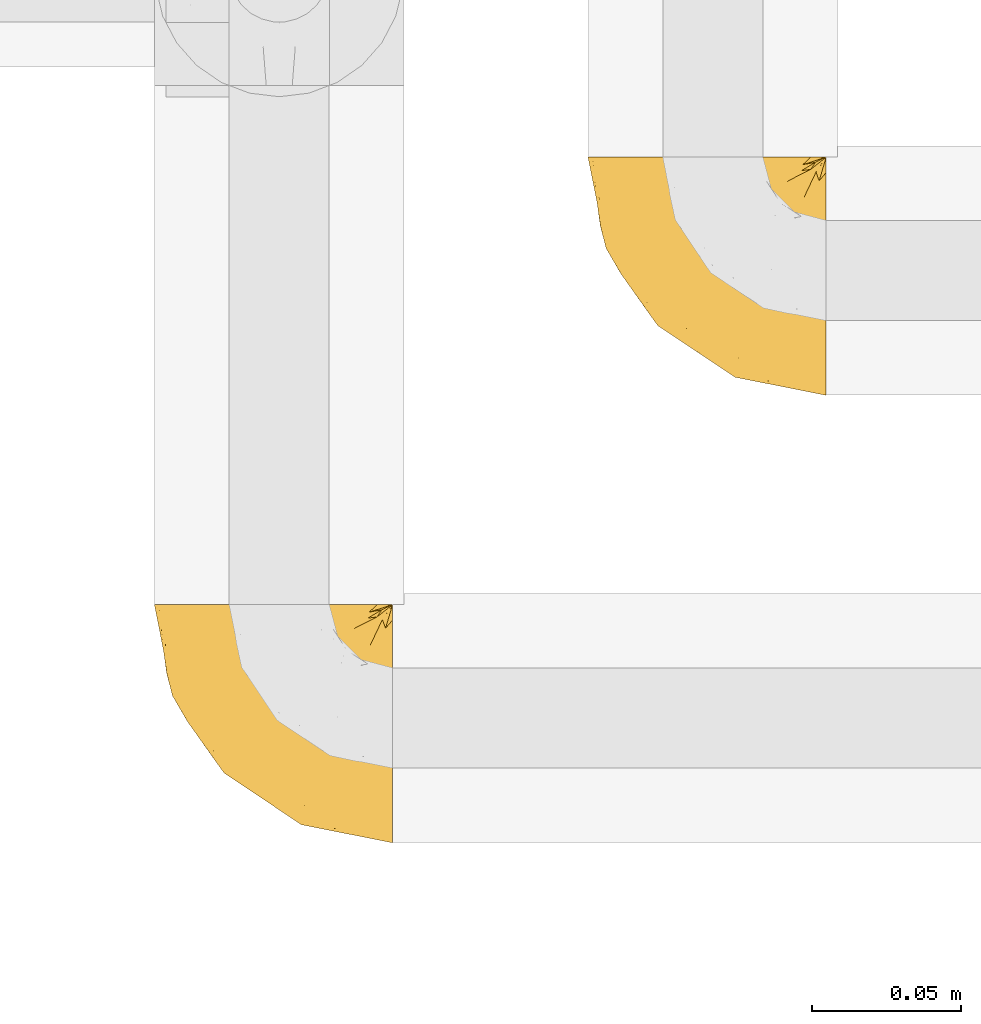
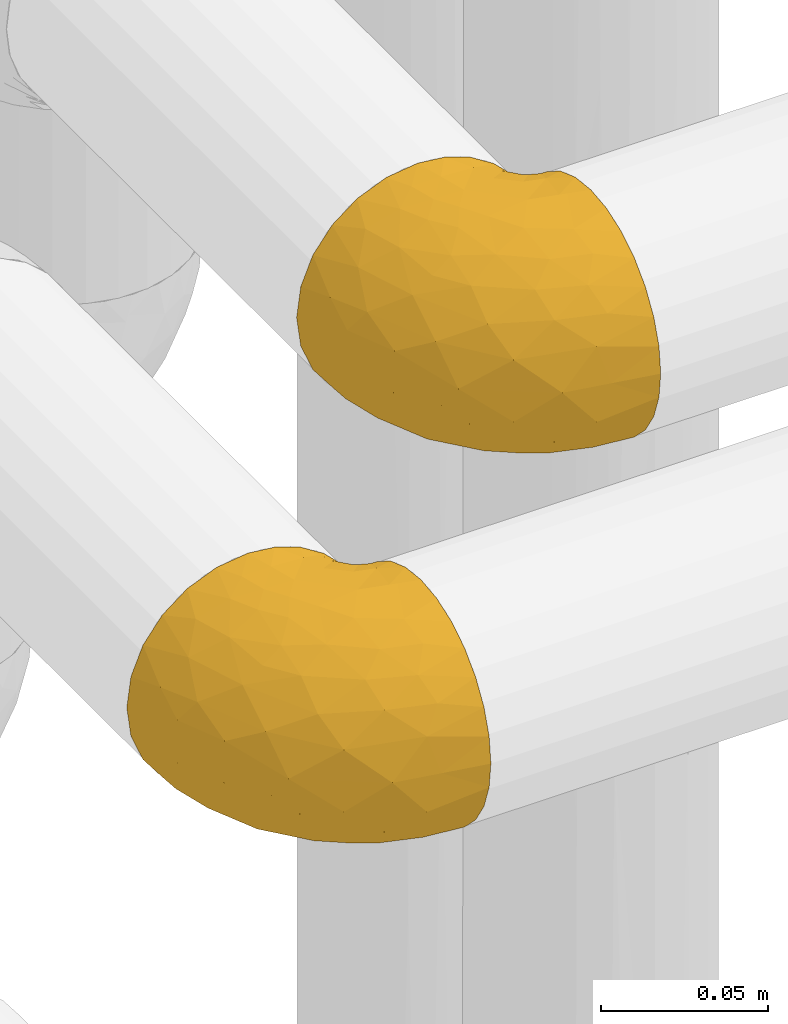
# One storey, part 57 of 827: 2 coverings.
"""IFC2X3 building model written with IfcOpenShell, lengths in millimetres."""

from ifc_helpers import new_model, entity, si_unit, converted_unit, derived_unit, direction, frame, origin, place, context, subcontext, project, spatial, faceted_brep, element, save


model = new_model("IFC2X3")

# Units and contexts
model_context = context("Model", 3, precision=0.01, world=origin(), true_north=direction((6.12303176911189e-17, 1.0)))
body_context = subcontext(model_context, "Body", "Model", "MODEL_VIEW")
ifc_project = project(units=[si_unit("LENGTHUNIT", "METRE", prefix="MILLI"), si_unit("AREAUNIT", "SQUARE_METRE"), si_unit("VOLUMEUNIT", "CUBIC_METRE"), converted_unit("PLANEANGLEUNIT", "DEGREE", entity("IfcRatioMeasure", 0.0174532925199433), si_unit("PLANEANGLEUNIT", "RADIAN"), dimensions=[0, 0, 0, 0, 0, 0, 0]), si_unit("MASSUNIT", "GRAM", prefix="KILO"), derived_unit("MASSDENSITYUNIT", [(si_unit("MASSUNIT", "GRAM", prefix="KILO"), 1), (si_unit("LENGTHUNIT", "METRE"), -3)]), derived_unit("MOMENTOFINERTIAUNIT", [(si_unit("LENGTHUNIT", "METRE"), 4)]), si_unit("TIMEUNIT", "SECOND"), si_unit("FREQUENCYUNIT", "HERTZ"), si_unit("THERMODYNAMICTEMPERATUREUNIT", "DEGREE_CELSIUS"), derived_unit("THERMALTRANSMITTANCEUNIT", [(si_unit("MASSUNIT", "GRAM", prefix="KILO"), 1), (si_unit("THERMODYNAMICTEMPERATUREUNIT", "KELVIN"), -1), (si_unit("TIMEUNIT", "SECOND"), -3)]), derived_unit("VOLUMETRICFLOWRATEUNIT", [(si_unit("LENGTHUNIT", "METRE"), 3), (si_unit("TIMEUNIT", "SECOND"), -1)]), derived_unit("MASSFLOWRATEUNIT", [(si_unit("MASSUNIT", "GRAM", prefix="KILO"), 1), (si_unit("TIMEUNIT", "SECOND"), -1)]), derived_unit("ROTATIONALFREQUENCYUNIT", [(si_unit("TIMEUNIT", "SECOND"), -1)]), si_unit("ELECTRICCURRENTUNIT", "AMPERE"), si_unit("ELECTRICVOLTAGEUNIT", "VOLT"), si_unit("POWERUNIT", "WATT"), si_unit("FORCEUNIT", "NEWTON", prefix="KILO"), si_unit("ILLUMINANCEUNIT", "LUX"), si_unit("LUMINOUSFLUXUNIT", "LUMEN"), si_unit("LUMINOUSINTENSITYUNIT", "CANDELA"), derived_unit("USERDEFINED", [(si_unit("MASSUNIT", "GRAM", prefix="KILO"), -1), (si_unit("LENGTHUNIT", "METRE"), -2), (si_unit("TIMEUNIT", "SECOND"), 3), (si_unit("LUMINOUSFLUXUNIT", "LUMEN"), 1)]), derived_unit("LINEARVELOCITYUNIT", [(si_unit("LENGTHUNIT", "METRE"), 1), (si_unit("TIMEUNIT", "SECOND"), -1)]), si_unit("PRESSUREUNIT", "PASCAL"), derived_unit("USERDEFINED", [(si_unit("LENGTHUNIT", "METRE"), -2), (si_unit("MASSUNIT", "GRAM", prefix="KILO"), 1), (si_unit("TIMEUNIT", "SECOND"), -2)]), derived_unit("LINEARFORCEUNIT", [(si_unit("MASSUNIT", "GRAM", prefix="KILO"), 1), (si_unit("LENGTHUNIT", "METRE"), 1), (si_unit("TIMEUNIT", "SECOND"), -2), (si_unit("LENGTHUNIT", "METRE"), -1)]), derived_unit("PLANARFORCEUNIT", [(si_unit("MASSUNIT", "GRAM", prefix="KILO"), 1), (si_unit("LENGTHUNIT", "METRE"), 1), (si_unit("TIMEUNIT", "SECOND"), -2), (si_unit("LENGTHUNIT", "METRE"), -2)])], contexts=[model_context])

# Site, building, storey
site_placement = place(None, origin())
site = spatial("IfcSite", under=ifc_project, at=site_placement, CompositionType="ELEMENT")
building_placement = place(site_placement, origin())
building = spatial("IfcBuilding", under=site, at=building_placement, CompositionType="ELEMENT")
storey_placement = place(building_placement, frame((0.0, 0.0, 28200.0)))
storey = spatial("IfcBuildingStorey", under=building, at=storey_placement, Name="08", CompositionType="ELEMENT", Elevation=28200.0)

# Coverings
covering_1_placement = place(storey_placement, frame((19224.04, 9449.35, 2953.79)))
element("IfcCovering", 1, at=covering_1_placement, inside=storey, Name=":ADSK_", ObjectType=":ADSK_", PredefinedType="INSULATION", context=body_context, shape_type="Brep", body=[
    faceted_brep([(81.45, 34.13, 84.25), (81.45, 25.28, 81.15), (81.45, 17.35, 76.16), (81.45, 10.72, 69.53), (81.45, 5.74, 61.6), (81.45, 2.64, 52.76), (81.45, 1.6, 43.45), (81.45, 2.65, 34.13), (81.44, 5.74, 25.28), (81.44, 10.73, 17.35), (81.44, 17.36, 10.72), (81.44, 25.29, 5.74), (81.44, 34.14, 2.64), (81.44, 43.44, 1.6), (81.44, 52.81, 2.66), (81.44, 61.71, 5.79), (81.44, 69.67, 10.83), (81.44, 76.31, 17.53), (81.45, 81.27, 61.36), (81.45, 76.3, 69.37), (81.45, 69.66, 76.07), (81.45, 61.69, 81.11), (81.45, 52.8, 84.24), (81.45, 43.45, 85.3), (81.44, 81.27, 25.53), (81.44, 81.27, 26.45), (32.61, 81.45, 83.87), (43.45, 81.45, 85.3), (52.81, 81.45, 84.23), (61.7, 81.45, 81.1), (69.67, 81.45, 76.06), (76.3, 81.45, 69.37), (81.27, 81.45, 61.36), (81.27, 81.45, 60.44), (81.27, 81.45, 59.12), (81.27, 81.45, 58.0), (81.27, 81.45, 56.88), (81.27, 81.45, 55.76), (81.27, 81.45, 54.64), (81.27, 81.45, 53.52), (81.27, 81.45, 52.4), (81.27, 81.45, 51.28), (81.27, 81.45, 50.16), (81.27, 81.45, 49.04), (81.27, 81.45, 47.92), (81.27, 81.45, 46.8), (81.27, 81.45, 45.68), (81.27, 81.45, 44.56), (81.27, 81.45, 43.44), (81.27, 81.45, 42.12), (81.27, 81.45, 40.8), (81.27, 81.45, 39.48), (81.27, 81.45, 38.16), (81.27, 81.44, 36.84), (81.27, 81.44, 35.52), (81.27, 81.44, 34.2), (81.27, 81.44, 32.88), (81.27, 81.44, 31.96), (81.27, 81.44, 31.04), (81.27, 81.44, 30.13), (81.27, 81.44, 29.21), (81.27, 81.44, 28.29), (81.27, 81.44, 27.37), (81.27, 81.44, 26.45), (81.27, 81.44, 25.53), (76.3, 81.44, 17.52), (69.67, 81.44, 10.83), (61.7, 81.44, 5.79), (52.81, 81.44, 2.66), (43.44, 81.44, 1.6), (32.61, 81.44, 3.02), (22.52, 81.44, 7.2), (13.85, 81.44, 13.85), (7.2, 81.44, 22.52), (3.02, 81.44, 32.61), (1.6, 81.45, 43.45), (3.02, 81.45, 54.28), (7.2, 81.45, 64.37), (13.85, 81.45, 73.04), (22.52, 81.45, 79.69), (81.31, 81.33, 54.08), (81.33, 81.32, 55.16), (81.31, 81.33, 36.18), (81.45, 81.27, 36.09), (81.32, 81.32, 35.13), (81.31, 81.33, 44.0), (81.32, 81.32, 45.08), (81.32, 81.32, 61.36), (81.32, 81.32, 59.98), (81.45, 81.27, 45.34), (81.32, 81.32, 46.18), (81.45, 81.27, 60.44), (81.44, 81.27, 27.37), (81.32, 81.32, 26.74), (81.32, 81.32, 47.36), (81.45, 81.27, 46.66), (81.32, 81.32, 29.67), (81.45, 81.27, 29.49), (81.3, 81.34, 28.72), (81.32, 81.32, 39.77), (81.33, 81.31, 52.96), (81.32, 81.33, 51.84), (81.33, 81.31, 40.8), (81.32, 81.32, 41.87), (81.45, 81.27, 44.02), (81.32, 81.33, 42.94), (81.32, 81.32, 27.77), (81.31, 81.33, 48.4), (81.45, 81.27, 59.52), (81.32, 81.32, 37.21), (81.31, 81.33, 33.54), (81.45, 81.27, 34.77), (81.45, 81.27, 33.45), (81.32, 81.32, 32.49), (81.32, 81.32, 30.69), (81.45, 81.27, 30.81), (81.32, 81.32, 50.68), (81.33, 81.31, 49.6), (81.32, 81.32, 56.32), (81.31, 81.33, 57.44), (81.44, 81.27, 28.17), (81.33, 81.31, 58.88), (81.32, 81.32, 25.53), (81.36, 81.3, 61.36), (81.4, 81.29, 61.36), (81.4, 81.29, 25.53), (81.36, 81.3, 25.53), (81.29, 81.4, 61.36), (81.3, 81.36, 61.36), (81.3, 81.36, 25.53), (81.29, 81.4, 25.53), (81.45, 81.27, 58.6), (81.45, 81.27, 57.68), (81.45, 81.27, 55.84), (81.45, 81.27, 56.76), (81.45, 81.27, 54.93), (81.45, 81.27, 40.06), (81.45, 81.27, 38.74), (81.45, 81.27, 42.7), (81.45, 81.27, 53.09), (81.45, 81.27, 52.17), (81.45, 81.27, 54.01), (81.45, 81.27, 48.49), (81.45, 81.27, 47.58), (81.45, 81.27, 49.41), (81.45, 81.27, 51.25), (81.35, 81.3, 31.59), (81.45, 81.27, 32.13), (81.45, 81.27, 50.33), (81.31, 81.33, 38.71), (81.45, 81.27, 41.38), (81.45, 81.27, 37.42), (58.5, 74.06, 3.97), (71.94, 45.99, 1.6), (74.57, 58.35, 3.97), (73.93, 67.76, 8.09), (78.18, 66.18, 8.09), (78.04, 76.46, 16.43), (76.23, 77.33, 15.73), (45.99, 71.94, 1.6), (74.01, 72.25, 10.79), (73.57, 78.91, 13.99), (66.65, 76.42, 8.08), (79.09, 73.52, 14.0), (73.14, 76.9, 12.83), (60.34, 65.25, 3.18), (48.54, 62.44, 1.6), (68.67, 67.71, 6.28), (67.22, 59.38, 3.28), (62.44, 48.53, 1.6), (45.36, 74.31, 1.6), (55.49, 55.49, 1.6), (77.84, 79.73, 19.06), (68.16, 73.23, 8.08), (74.31, 45.36, 1.6), (38.77, 15.81, 32.11), (62.1, 6.4, 29.62), (50.89, 7.67, 43.45), (36.91, 68.46, 2.45), (40.37, 59.33, 2.5), (27.86, 48.7, 9.74), (15.77, 53.94, 17.97), (20.13, 65.01, 10.24), (31.54, 60.77, 4.78), (28.25, 72.06, 4.78), (57.26, 26.25, 8.01), (69.99, 22.28, 8.01), (64.58, 16.0, 13.85), (50.64, 46.92, 2.42), (51.97, 14.19, 21.18), (5.72, 58.46, 35.73), (7.42, 61.5, 27.43), (66.14, 4.64, 43.45), (11.35, 68.93, 17.97), (21.64, 29.62, 35.71), (28.57, 24.85, 29.47), (55.38, 38.55, 3.41), (68.51, 31.27, 3.94), (67.48, 9.35, 21.18), (40.78, 37.15, 7.93), (41.53, 47.07, 4.26), (46.11, 26.49, 11.76), (40.32, 23.0, 18.31), (38.36, 19.4, 24.94), (11.84, 48.06, 28.78), (12.56, 42.46, 35.82), (7.67, 50.89, 43.45), (19.39, 35.78, 28.38), (24.98, 24.98, 43.45), (37.94, 16.33, 43.45), (4.64, 66.14, 43.45), (28.09, 30.96, 21.21), (23.73, 41.83, 16.48), (34.03, 33.28, 13.85), (16.33, 37.94, 43.45), (29.29, 67.39, 82.11), (5.77, 58.47, 51.41), (21.44, 32.5, 57.45), (38.8, 15.79, 54.78), (64.58, 15.99, 73.03), (67.49, 9.35, 65.71), (22.9, 56.91, 76.65), (12.54, 63.5, 68.92), (20.04, 44.08, 68.01), (57.26, 26.24, 78.88), (69.99, 22.27, 78.88), (68.51, 31.26, 82.95), (34.54, 23.95, 64.44), (38.81, 63.79, 84.5), (48.54, 62.45, 85.3), (45.99, 71.95, 85.3), (74.31, 45.36, 85.3), (5.36, 67.83, 57.84), (18.96, 70.28, 76.65), (12.79, 42.11, 51.19), (62.11, 6.39, 57.26), (33.14, 43.55, 78.15), (33.44, 58.03, 82.35), (51.98, 14.18, 65.71), (43.42, 56.35, 84.61), (48.62, 48.09, 84.36), (62.45, 48.54, 85.3), (55.49, 55.49, 85.3), (49.68, 21.78, 73.03), (55.37, 38.55, 83.48), (71.95, 45.99, 85.3), (36.37, 72.79, 84.54), (34.04, 33.26, 73.03), (44.1, 35.53, 79.54), (9.99, 53.66, 59.46), (26.41, 43.03, 73.51), (39.2, 49.68, 82.57), (58.5, 74.06, 82.92), (67.22, 59.37, 83.62), (74.57, 58.34, 82.92), (73.92, 67.75, 78.81), (73.57, 78.91, 72.9), (73.14, 76.9, 74.06), (66.19, 78.08, 78.81), (68.16, 73.23, 78.81), (77.84, 79.73, 67.83), (76.23, 77.34, 71.15), (79.08, 73.51, 72.91), (78.04, 76.45, 70.47), (77.18, 66.41, 78.81), (68.66, 67.7, 80.62), (74.0, 72.24, 76.11), (60.34, 65.26, 83.71)], [[[0, 1, 2, 3, 4, 5, 6, 7, 8, 9, 10, 11, 12, 13, 14, 15, 16, 17, 18, 19, 20, 21, 22, 23]], [[17, 24, 25]], [[26, 27, 28, 29, 30, 31, 32, 33, 34, 35, 36, 37, 38, 39, 40, 41, 42, 43, 44, 45, 46, 47, 48, 49, 50, 51, 52, 53, 54, 55, 56, 57, 58, 59, 60, 61, 62, 63, 64, 65, 66, 67, 68, 69, 70, 71, 72, 73, 74, 75, 76, 77, 78, 79]], [[80, 38, 81]], [[82, 83, 84]], [[84, 55, 54]], [[85, 47, 86]], [[33, 87, 88]], [[89, 86, 90]], [[87, 91, 88]], [[92, 25, 93]], [[90, 94, 95]], [[96, 97, 98]], [[51, 50, 99]], [[40, 100, 101]], [[86, 46, 90]], [[102, 50, 103]], [[104, 105, 85]], [[92, 93, 106]], [[94, 44, 107]], [[48, 85, 105]], [[85, 86, 104]], [[88, 91, 108]], [[82, 53, 109]], [[110, 84, 111]], [[112, 113, 110]], [[114, 115, 96]], [[116, 117, 42]], [[38, 37, 81]], [[118, 36, 119]], [[106, 120, 92]], [[88, 108, 121]], [[35, 121, 119]], [[98, 97, 120]], [[122, 93, 25]], [[119, 36, 35]], [[106, 61, 98]], [[91, 87, 123, 124]], [[25, 125, 126, 122]], [[33, 32, 127, 128, 87]], [[63, 122, 129, 130, 64]], [[56, 110, 113]], [[59, 114, 96]], [[88, 34, 33]], [[34, 88, 121]], [[25, 24, 125]], [[93, 63, 62]], [[131, 132, 121, 108]], [[35, 34, 121]], [[133, 81, 118]], [[47, 85, 48]], [[132, 119, 121]], [[132, 134, 119]], [[119, 134, 118]], [[118, 81, 37]], [[39, 38, 80]], [[81, 135, 80]], [[37, 36, 118]], [[60, 96, 98]], [[59, 96, 60]], [[97, 96, 115]], [[99, 136, 137]], [[89, 104, 86]], [[103, 105, 138]], [[104, 138, 105]], [[95, 89, 90]], [[86, 47, 46]], [[105, 49, 48]], [[49, 105, 103]], [[139, 140, 100, 141]], [[90, 45, 94]], [[142, 143, 107, 144]], [[117, 107, 43]], [[94, 107, 143]], [[44, 94, 45]], [[90, 46, 45]], [[116, 101, 145]], [[100, 40, 39]], [[141, 100, 80]], [[39, 80, 100]], [[146, 147, 115]], [[106, 62, 61]], [[106, 98, 120]], [[61, 60, 98]], [[117, 144, 107]], [[116, 148, 117]], [[43, 42, 117]], [[107, 44, 43]], [[99, 149, 51]], [[140, 145, 101]], [[41, 101, 116]], [[40, 101, 41]], [[116, 42, 41]], [[140, 101, 100]], [[145, 148, 116]], [[49, 103, 50]], [[150, 103, 138]], [[136, 99, 102]], [[102, 103, 150]], [[149, 99, 137]], [[102, 150, 136]], [[102, 99, 50]], [[149, 52, 51]], [[134, 133, 118]], [[83, 82, 109]], [[82, 54, 53]], [[109, 149, 151]], [[151, 83, 109]], [[83, 111, 84]], [[54, 82, 84]], [[55, 110, 56]], [[110, 55, 84]], [[137, 151, 149]], [[109, 53, 52]], [[147, 113, 112]], [[111, 112, 110]], [[113, 147, 146]], [[114, 58, 146]], [[146, 58, 57]], [[57, 56, 113]], [[106, 93, 62]], [[63, 93, 122]], [[141, 80, 135]], [[81, 133, 135]], [[58, 114, 59]], [[113, 146, 57]], [[114, 146, 115]], [[143, 95, 94]], [[117, 148, 144]], [[52, 149, 109]], [[67, 152, 68]], [[14, 153, 154]], [[155, 156, 154]], [[157, 158, 122]], [[159, 68, 152]], [[160, 157, 155]], [[161, 162, 66]], [[66, 162, 67]], [[125, 17, 163]], [[66, 65, 161]], [[162, 161, 164]], [[157, 163, 155]], [[152, 165, 166]], [[163, 17, 16]], [[125, 24, 17]], [[155, 167, 160]], [[65, 130, 161]], [[156, 15, 154]], [[163, 156, 155]], [[155, 154, 168]], [[168, 154, 169]], [[156, 16, 15]], [[157, 125, 163]], [[15, 14, 154]], [[68, 159, 170, 69]], [[171, 165, 168]], [[158, 164, 172]], [[65, 64, 130]], [[157, 126, 125]], [[173, 164, 158]], [[173, 160, 167]], [[171, 166, 165]], [[168, 165, 167]], [[168, 169, 171]], [[152, 173, 165]], [[167, 155, 168]], [[165, 173, 167]], [[160, 173, 158]], [[172, 130, 129]], [[129, 122, 158]], [[158, 157, 160]], [[152, 166, 159]], [[173, 152, 162]], [[67, 162, 152]], [[14, 13, 174, 153]], [[153, 169, 154]], [[16, 156, 163]], [[157, 122, 126]], [[162, 164, 173]], [[172, 164, 161]], [[130, 172, 161]], [[158, 172, 129]], [[175, 176, 177]], [[178, 166, 179]], [[180, 181, 182]], [[183, 184, 178]], [[185, 186, 187]], [[171, 188, 179]], [[174, 13, 12]], [[189, 176, 175]], [[190, 74, 191]], [[176, 7, 192]], [[193, 73, 72]], [[71, 184, 182]], [[71, 182, 72]], [[73, 193, 191]], [[184, 71, 70]], [[175, 194, 195]], [[196, 169, 197]], [[174, 12, 197]], [[9, 8, 198]], [[187, 10, 9]], [[197, 169, 153, 174]], [[197, 12, 11]], [[186, 197, 11]], [[199, 180, 200]], [[197, 185, 196]], [[201, 189, 202]], [[201, 187, 189]], [[195, 203, 175]], [[191, 204, 190]], [[176, 8, 7]], [[177, 176, 192]], [[189, 198, 176]], [[73, 191, 74]], [[198, 187, 9]], [[205, 206, 190]], [[10, 186, 11]], [[181, 207, 204]], [[208, 175, 177, 209]], [[74, 190, 210]], [[211, 212, 213]], [[190, 204, 205]], [[180, 182, 183]], [[193, 182, 181]], [[70, 69, 170]], [[196, 185, 199]], [[196, 200, 188]], [[7, 6, 192]], [[176, 198, 8]], [[187, 198, 189]], [[187, 186, 10]], [[197, 186, 185]], [[200, 180, 183]], [[180, 213, 212]], [[179, 183, 178]], [[185, 201, 199]], [[210, 190, 206]], [[210, 75, 74]], [[205, 204, 207]], [[194, 205, 207]], [[194, 214, 205]], [[195, 194, 207]], [[208, 194, 175]], [[207, 211, 195]], [[202, 203, 211]], [[212, 207, 181]], [[202, 211, 213]], [[201, 202, 213]], [[189, 175, 203]], [[199, 201, 213]], [[187, 201, 185]], [[180, 199, 213]], [[196, 199, 200]], [[211, 203, 195]], [[189, 203, 202]], [[207, 212, 211]], [[180, 212, 181]], [[214, 194, 208]], [[214, 206, 205]], [[196, 188, 169]], [[181, 204, 191]], [[182, 193, 72]], [[191, 193, 181]], [[178, 70, 170]], [[182, 184, 183]], [[70, 178, 184]], [[178, 170, 159, 166]], [[171, 179, 166]], [[200, 183, 179]], [[179, 188, 200]], [[169, 188, 171]], [[79, 215, 26]], [[206, 216, 210]], [[217, 208, 218]], [[216, 76, 210]], [[219, 220, 3]], [[221, 222, 223]], [[224, 225, 226]], [[227, 223, 217]], [[228, 229, 230]], [[0, 231, 226]], [[232, 222, 77]], [[0, 23, 231]], [[78, 233, 79]], [[79, 233, 215]], [[1, 0, 226]], [[208, 217, 234]], [[218, 177, 235]], [[221, 236, 237]], [[238, 220, 219]], [[2, 219, 3]], [[76, 216, 232]], [[235, 4, 220]], [[235, 192, 5]], [[2, 1, 225]], [[228, 239, 229]], [[240, 241, 242]], [[243, 238, 219]], [[224, 226, 244]], [[226, 241, 244]], [[4, 235, 5]], [[77, 222, 78]], [[225, 219, 2]], [[218, 235, 238]], [[243, 219, 224]], [[218, 227, 217]], [[4, 3, 220]], [[218, 208, 209, 177]], [[226, 231, 245, 241]], [[215, 228, 246]], [[247, 248, 236]], [[248, 224, 244]], [[223, 222, 249]], [[233, 222, 221]], [[242, 239, 240]], [[248, 247, 243]], [[217, 223, 249]], [[250, 247, 236]], [[216, 234, 249]], [[218, 238, 227]], [[192, 235, 177]], [[192, 6, 5]], [[26, 246, 27]], [[235, 220, 238]], [[226, 225, 1]], [[219, 225, 224]], [[240, 248, 244]], [[239, 242, 229]], [[236, 248, 251]], [[76, 75, 210]], [[234, 216, 206]], [[216, 249, 232]], [[234, 206, 214, 208]], [[249, 234, 217]], [[222, 232, 249]], [[77, 76, 232]], [[246, 228, 230]], [[237, 228, 215]], [[243, 227, 238]], [[223, 227, 247]], [[27, 246, 230]], [[215, 246, 26]], [[248, 243, 224]], [[227, 243, 247]], [[237, 236, 251]], [[250, 221, 223]], [[222, 233, 78]], [[215, 233, 221]], [[221, 237, 215]], [[239, 237, 251]], [[237, 239, 228]], [[239, 251, 240]], [[248, 240, 251]], [[241, 240, 244]], [[221, 250, 236]], [[223, 247, 250]], [[28, 230, 252]], [[253, 254, 255]], [[127, 31, 256]], [[257, 258, 259]], [[260, 256, 257]], [[260, 261, 128]], [[29, 28, 252]], [[19, 124, 262]], [[263, 124, 123, 87]], [[256, 31, 30]], [[252, 258, 29]], [[253, 241, 254]], [[254, 245, 22]], [[127, 32, 31]], [[21, 20, 264]], [[254, 264, 255]], [[258, 256, 30]], [[255, 264, 262]], [[29, 258, 30]], [[265, 255, 266]], [[255, 262, 263]], [[255, 265, 253]], [[19, 262, 20]], [[22, 245, 231, 23]], [[253, 267, 242]], [[254, 22, 21]], [[266, 259, 265]], [[19, 18, 124]], [[263, 87, 261]], [[127, 256, 260]], [[257, 259, 261]], [[267, 253, 265]], [[229, 267, 252]], [[242, 267, 229]], [[242, 241, 253]], [[252, 267, 259]], [[255, 263, 266]], [[259, 267, 265]], [[261, 87, 128]], [[263, 261, 266]], [[259, 266, 261]], [[230, 28, 27]], [[230, 229, 252]], [[259, 258, 252]], [[254, 241, 245]], [[21, 264, 254]], [[20, 262, 264]], [[124, 263, 262]], [[258, 257, 256]], [[261, 260, 257]], [[127, 260, 128]], [[17, 25, 92, 120, 97, 115, 147, 112, 111, 83, 151, 137, 136, 150, 138, 104, 89, 95, 143, 142, 144, 148, 145, 140, 139, 141, 135, 133, 134, 132, 131, 108, 91]], [[17, 91, 18]], [[91, 124, 18]]]),
])
covering_2_placement = place(storey_placement, frame((19078.69, 9299.35, 2953.02)))
element("IfcCovering", 2, at=covering_2_placement, inside=storey, Name=":ADSK_", ObjectType=":ADSK_", PredefinedType="INSULATION", context=body_context, shape_type="Brep", body=[
    faceted_brep([(81.45, 25.28, 81.15), (81.45, 17.35, 76.16), (81.45, 10.72, 69.53), (81.45, 5.74, 61.6), (81.45, 2.64, 52.75), (81.45, 1.6, 43.45), (81.45, 2.65, 34.13), (81.45, 5.74, 25.28), (81.45, 10.73, 17.35), (81.45, 17.36, 10.72), (81.45, 25.29, 5.74), (81.45, 34.14, 2.64), (81.45, 43.45, 1.6), (81.45, 52.82, 2.66), (81.45, 61.71, 5.79), (81.45, 69.67, 10.83), (81.45, 76.31, 17.53), (81.45, 81.27, 25.53), (81.45, 81.27, 26.45), (81.45, 81.27, 27.37), (81.45, 81.27, 28.17), (81.45, 81.27, 29.49), (81.45, 81.27, 30.81), (81.45, 81.27, 32.13), (81.45, 81.27, 33.45), (81.45, 81.27, 34.78), (81.45, 81.27, 36.1), (81.45, 81.27, 37.42), (81.45, 81.27, 38.74), (81.45, 81.27, 40.06), (81.45, 81.27, 41.38), (81.45, 81.27, 42.7), (81.45, 81.27, 44.02), (81.45, 81.27, 45.34), (81.45, 81.27, 46.66), (81.45, 81.27, 47.58), (81.45, 81.27, 48.5), (81.45, 81.27, 49.41), (81.45, 81.27, 50.33), (81.45, 81.27, 51.25), (81.45, 81.27, 52.17), (81.45, 81.27, 53.09), (81.45, 81.27, 54.01), (81.45, 81.27, 54.93), (81.45, 81.27, 55.85), (81.45, 81.27, 56.76), (81.45, 81.27, 57.68), (81.45, 81.27, 58.6), (81.45, 81.27, 59.52), (81.45, 81.27, 60.44), (81.45, 81.27, 61.36), (81.45, 76.3, 69.37), (81.45, 69.66, 76.07), (81.45, 61.69, 81.11), (81.45, 52.8, 84.24), (81.45, 43.45, 85.3), (81.45, 34.13, 84.24), (76.3, 81.45, 17.52), (69.67, 81.45, 10.83), (61.7, 81.45, 5.79), (52.81, 81.45, 2.66), (43.45, 81.45, 1.6), (32.61, 81.45, 3.02), (22.52, 81.45, 7.2), (13.85, 81.45, 13.85), (7.2, 81.45, 22.52), (3.02, 81.45, 32.61), (1.6, 81.45, 43.45), (3.02, 81.45, 54.28), (7.2, 81.45, 64.37), (13.85, 81.45, 73.04), (22.52, 81.45, 79.69), (32.61, 81.45, 83.87), (43.45, 81.45, 85.3), (52.81, 81.45, 84.23), (61.7, 81.45, 81.1), (69.67, 81.45, 76.06), (76.3, 81.45, 69.37), (81.27, 81.45, 61.36), (81.27, 81.45, 60.44), (81.27, 81.45, 59.12), (81.27, 81.45, 58.0), (81.27, 81.45, 56.88), (81.27, 81.45, 55.76), (81.27, 81.45, 54.64), (81.27, 81.45, 53.52), (81.27, 81.45, 52.4), (81.27, 81.45, 51.28), (81.27, 81.45, 50.16), (81.27, 81.45, 49.04), (81.27, 81.45, 47.92), (81.27, 81.45, 46.8), (81.27, 81.45, 45.68), (81.27, 81.45, 44.56), (81.27, 81.45, 43.45), (81.27, 81.45, 42.12), (81.27, 81.45, 40.8), (81.27, 81.45, 39.48), (81.27, 81.45, 38.16), (81.27, 81.45, 36.84), (81.27, 81.45, 35.52), (81.27, 81.45, 34.2), (81.27, 81.45, 32.88), (81.27, 81.45, 31.96), (81.27, 81.45, 31.05), (81.27, 81.45, 30.13), (81.27, 81.45, 29.21), (81.27, 81.45, 28.29), (81.27, 81.45, 27.37), (81.27, 81.45, 26.45), (81.27, 81.45, 25.53), (81.31, 81.33, 54.08), (81.33, 81.32, 55.16), (81.31, 81.33, 36.18), (81.32, 81.32, 35.13), (81.31, 81.33, 44.01), (81.32, 81.32, 45.08), (81.32, 81.32, 61.36), (81.32, 81.32, 59.98), (81.32, 81.32, 46.18), (81.32, 81.32, 26.74), (81.32, 81.32, 47.36), (81.32, 81.32, 29.67), (81.3, 81.34, 28.72), (81.32, 81.32, 39.77), (81.33, 81.31, 52.96), (81.31, 81.33, 51.84), (81.33, 81.31, 40.8), (81.32, 81.32, 41.87), (81.32, 81.33, 42.94), (81.32, 81.32, 27.77), (81.31, 81.33, 48.4), (81.32, 81.32, 37.21), (81.31, 81.33, 33.54), (81.32, 81.32, 32.49), (81.32, 81.32, 30.69), (81.32, 81.32, 50.69), (81.33, 81.31, 49.6), (81.32, 81.32, 56.32), (81.31, 81.33, 57.44), (81.33, 81.31, 58.88), (81.32, 81.32, 25.53), (81.36, 81.3, 61.36), (81.4, 81.29, 61.36), (81.4, 81.29, 25.53), (81.36, 81.3, 25.53), (81.29, 81.4, 61.36), (81.3, 81.36, 61.36), (81.3, 81.36, 25.53), (81.29, 81.4, 25.53), (81.35, 81.3, 31.59), (81.31, 81.33, 38.71), (58.5, 74.06, 3.97), (71.95, 45.99, 1.6), (74.57, 58.35, 3.97), (73.93, 67.76, 8.09), (78.18, 66.18, 8.09), (78.04, 76.46, 16.43), (76.23, 77.33, 15.73), (45.99, 71.95, 1.6), (74.01, 72.25, 10.79), (73.57, 78.91, 13.99), (66.66, 76.42, 8.08), (79.09, 73.52, 14.0), (73.14, 76.9, 12.83), (60.34, 65.25, 3.18), (48.54, 62.45, 1.6), (45.36, 74.31, 1.6), (67.22, 59.38, 3.28), (62.45, 48.54, 1.6), (68.67, 67.72, 6.28), (55.49, 55.49, 1.6), (77.84, 79.73, 19.06), (68.16, 73.23, 8.08), (74.31, 45.36, 1.6), (38.78, 15.81, 32.11), (62.1, 6.4, 29.62), (50.89, 7.67, 43.45), (36.91, 68.46, 2.45), (40.37, 59.33, 2.5), (27.86, 48.7, 9.73), (15.77, 53.94, 17.97), (20.13, 65.02, 10.24), (31.54, 60.77, 4.78), (28.25, 72.07, 4.78), (57.26, 26.25, 8.01), (69.99, 22.29, 8.01), (64.58, 16.0, 13.85), (50.64, 46.93, 2.42), (51.97, 14.19, 21.17), (5.72, 58.46, 35.73), (7.42, 61.51, 27.43), (66.14, 4.64, 43.45), (11.35, 68.93, 17.97), (21.64, 29.62, 35.71), (28.57, 24.85, 29.47), (55.38, 38.55, 3.41), (68.51, 31.27, 3.94), (67.48, 9.35, 21.17), (40.78, 37.15, 7.92), (41.53, 47.07, 4.25), (46.11, 26.49, 11.75), (40.32, 23.01, 18.31), (38.36, 19.4, 24.94), (11.84, 48.06, 28.78), (12.56, 42.46, 35.82), (7.67, 50.89, 43.45), (19.39, 35.78, 28.38), (24.98, 24.98, 43.45), (37.94, 16.33, 43.45), (4.64, 66.14, 43.45), (28.09, 30.96, 21.21), (23.73, 41.83, 16.48), (34.03, 33.28, 13.85), (16.33, 37.94, 43.45), (29.29, 67.39, 82.11), (5.77, 58.47, 51.41), (21.44, 32.5, 57.45), (38.8, 15.79, 54.78), (64.58, 15.99, 73.03), (67.49, 9.34, 65.7), (22.9, 56.91, 76.65), (12.54, 63.5, 68.92), (20.04, 44.08, 68.01), (57.26, 26.24, 78.88), (69.99, 22.27, 78.88), (68.51, 31.26, 82.94), (34.54, 23.95, 64.44), (38.81, 63.79, 84.49), (48.54, 62.45, 85.3), (45.99, 71.95, 85.3), (74.31, 45.36, 85.3), (5.36, 67.83, 57.84), (18.96, 70.28, 76.65), (12.79, 42.11, 51.19), (62.11, 6.39, 57.26), (33.14, 43.54, 78.14), (33.44, 58.03, 82.35), (51.98, 14.18, 65.7), (43.42, 56.34, 84.61), (48.62, 48.09, 84.36), (62.45, 48.54, 85.3), (55.49, 55.49, 85.3), (49.68, 21.78, 73.03), (55.37, 38.54, 83.48), (71.95, 45.99, 85.3), (36.37, 72.79, 84.54), (34.04, 33.26, 73.03), (44.1, 35.53, 79.54), (9.99, 53.66, 59.46), (26.41, 43.03, 73.5), (39.19, 49.68, 82.57), (58.5, 74.06, 82.92), (67.22, 59.37, 83.62), (74.57, 58.34, 82.92), (73.92, 67.75, 78.81), (73.57, 78.91, 72.9), (73.14, 76.9, 74.06), (66.19, 78.08, 78.81), (68.16, 73.23, 78.81), (77.84, 79.73, 67.83), (76.23, 77.34, 71.15), (79.08, 73.51, 72.91), (78.04, 76.45, 70.47), (77.18, 66.41, 78.81), (68.66, 67.7, 80.62), (74.0, 72.24, 76.11), (60.34, 65.25, 83.71)], [[[0, 1, 2, 3, 4, 5, 6, 7, 8, 9, 10, 11, 12, 13, 14, 15, 16, 17, 18, 19, 20, 21, 22, 23, 24, 25, 26, 27, 28, 29, 30, 31, 32, 33, 34, 35, 36, 37, 38, 39, 40, 41, 42, 43, 44, 45, 46, 47, 48, 49, 50, 51, 52, 53, 54, 55, 56]], [[57, 58, 59, 60, 61, 62, 63, 64, 65, 66, 67, 68, 69, 70, 71, 72, 73, 74, 75, 76, 77, 78, 79, 80, 81, 82, 83, 84, 85, 86, 87, 88, 89, 90, 91, 92, 93, 94, 95, 96, 97, 98, 99, 100, 101, 102, 103, 104, 105, 106, 107, 108, 109, 110]], [[111, 84, 112]], [[113, 26, 114]], [[114, 101, 100]], [[115, 93, 116]], [[79, 117, 118]], [[33, 116, 119]], [[117, 49, 118]], [[19, 18, 120]], [[119, 121, 34]], [[122, 21, 123]], [[97, 96, 124]], [[86, 125, 126]], [[116, 92, 119]], [[127, 96, 128]], [[32, 129, 115]], [[19, 120, 130]], [[121, 90, 131]], [[94, 115, 129]], [[115, 116, 32]], [[118, 49, 48]], [[113, 99, 132]], [[133, 114, 25]], [[24, 134, 133]], [[135, 22, 122]], [[136, 137, 88]], [[84, 83, 112]], [[138, 82, 139]], [[130, 20, 19]], [[118, 48, 140]], [[81, 140, 139]], [[123, 21, 20]], [[141, 120, 18]], [[139, 82, 81]], [[130, 107, 123]], [[49, 117, 142, 143, 50]], [[18, 17, 144, 145, 141]], [[79, 78, 146, 147, 117]], [[109, 141, 148, 149, 110]], [[102, 133, 134]], [[105, 135, 122]], [[118, 80, 79]], [[80, 118, 140]], [[120, 109, 108]], [[47, 46, 140, 48]], [[81, 80, 140]], [[44, 112, 138]], [[93, 115, 94]], [[46, 139, 140]], [[46, 45, 139]], [[139, 45, 138]], [[138, 112, 83]], [[85, 84, 111]], [[112, 43, 111]], [[83, 82, 138]], [[106, 122, 123]], [[105, 122, 106]], [[21, 122, 22]], [[124, 29, 28]], [[33, 32, 116]], [[128, 129, 31]], [[32, 31, 129]], [[34, 33, 119]], [[116, 93, 92]], [[129, 95, 94]], [[95, 129, 128]], [[41, 40, 125, 42]], [[119, 91, 121]], [[36, 35, 131, 37]], [[137, 131, 89]], [[121, 131, 35]], [[90, 121, 91]], [[119, 92, 91]], [[136, 126, 39]], [[125, 86, 85]], [[42, 125, 111]], [[85, 111, 125]], [[150, 23, 22]], [[130, 108, 107]], [[130, 123, 20]], [[107, 106, 123]], [[137, 37, 131]], [[136, 38, 137]], [[89, 88, 137]], [[131, 90, 89]], [[124, 151, 97]], [[40, 39, 126]], [[87, 126, 136]], [[86, 126, 87]], [[136, 88, 87]], [[40, 126, 125]], [[39, 38, 136]], [[95, 128, 96]], [[30, 128, 31]], [[29, 124, 127]], [[127, 128, 30]], [[151, 124, 28]], [[127, 30, 29]], [[127, 124, 96]], [[151, 98, 97]], [[45, 44, 138]], [[26, 113, 132]], [[113, 100, 99]], [[132, 151, 27]], [[27, 26, 132]], [[26, 25, 114]], [[100, 113, 114]], [[101, 133, 102]], [[133, 101, 114]], [[28, 27, 151]], [[132, 99, 98]], [[23, 134, 24]], [[25, 24, 133]], [[134, 23, 150]], [[135, 104, 150]], [[150, 104, 103]], [[103, 102, 134]], [[130, 120, 108]], [[109, 120, 141]], [[42, 111, 43]], [[112, 44, 43]], [[104, 135, 105]], [[134, 150, 103]], [[135, 150, 22]], [[35, 34, 121]], [[137, 38, 37]], [[98, 151, 132]], [[59, 152, 60]], [[13, 153, 154]], [[155, 156, 154]], [[157, 158, 141]], [[159, 60, 152]], [[160, 157, 155]], [[161, 162, 58]], [[58, 162, 59]], [[144, 16, 163]], [[58, 57, 161]], [[162, 161, 164]], [[157, 163, 155]], [[163, 16, 15]], [[57, 149, 161]], [[152, 165, 166]], [[157, 144, 163]], [[60, 159, 167, 61]], [[156, 14, 154]], [[163, 156, 155]], [[155, 154, 168]], [[168, 154, 169]], [[155, 170, 160]], [[57, 110, 149]], [[144, 17, 16]], [[156, 15, 14]], [[171, 165, 168]], [[158, 164, 172]], [[14, 13, 154]], [[157, 141, 145, 144]], [[173, 164, 158]], [[173, 160, 170]], [[171, 166, 165]], [[168, 165, 170]], [[168, 169, 171]], [[152, 173, 165]], [[170, 155, 168]], [[165, 173, 170]], [[160, 173, 158]], [[172, 149, 148]], [[148, 141, 158]], [[158, 157, 160]], [[152, 166, 159]], [[173, 152, 162]], [[59, 162, 152]], [[13, 12, 174, 153]], [[153, 169, 154]], [[15, 156, 163]], [[162, 164, 173]], [[172, 164, 161]], [[149, 172, 161]], [[158, 172, 148]], [[175, 176, 177]], [[178, 166, 179]], [[180, 181, 182]], [[183, 184, 178]], [[185, 186, 187]], [[171, 188, 179]], [[174, 12, 11]], [[189, 176, 175]], [[190, 66, 191]], [[176, 6, 192]], [[193, 65, 64]], [[63, 184, 182]], [[63, 182, 64]], [[65, 193, 191]], [[184, 63, 62]], [[175, 194, 195]], [[196, 169, 197]], [[174, 11, 197]], [[8, 7, 198]], [[187, 9, 8]], [[197, 169, 153, 174]], [[197, 11, 10]], [[186, 197, 10]], [[199, 180, 200]], [[197, 185, 196]], [[201, 189, 202]], [[201, 187, 189]], [[195, 203, 175]], [[191, 204, 190]], [[176, 7, 6]], [[177, 176, 192]], [[189, 198, 176]], [[65, 191, 66]], [[198, 187, 8]], [[205, 206, 190]], [[9, 186, 10]], [[181, 207, 204]], [[208, 175, 177, 209]], [[66, 190, 210]], [[211, 212, 213]], [[190, 204, 205]], [[180, 182, 183]], [[193, 182, 181]], [[62, 61, 167]], [[196, 185, 199]], [[196, 200, 188]], [[6, 5, 192]], [[176, 198, 7]], [[187, 198, 189]], [[187, 186, 9]], [[197, 186, 185]], [[200, 180, 183]], [[180, 213, 212]], [[179, 183, 178]], [[185, 201, 199]], [[210, 190, 206]], [[210, 67, 66]], [[205, 204, 207]], [[194, 205, 207]], [[194, 214, 205]], [[195, 194, 207]], [[208, 194, 175]], [[207, 211, 195]], [[202, 203, 211]], [[212, 207, 181]], [[202, 211, 213]], [[201, 202, 213]], [[189, 175, 203]], [[199, 201, 213]], [[187, 201, 185]], [[180, 199, 213]], [[196, 199, 200]], [[211, 203, 195]], [[189, 203, 202]], [[207, 212, 211]], [[180, 212, 181]], [[214, 194, 208]], [[214, 206, 205]], [[196, 188, 169]], [[181, 204, 191]], [[182, 193, 64]], [[191, 193, 181]], [[178, 62, 167]], [[182, 184, 183]], [[62, 178, 184]], [[178, 167, 159, 166]], [[171, 179, 166]], [[200, 183, 179]], [[179, 188, 200]], [[169, 188, 171]], [[71, 215, 72]], [[206, 216, 210]], [[217, 208, 218]], [[216, 68, 210]], [[219, 220, 2]], [[221, 222, 223]], [[224, 225, 226]], [[227, 223, 217]], [[228, 229, 230]], [[56, 231, 226]], [[232, 222, 69]], [[56, 55, 231]], [[70, 233, 71]], [[71, 233, 215]], [[0, 56, 226]], [[208, 217, 234]], [[218, 177, 235]], [[221, 236, 237]], [[238, 220, 219]], [[1, 219, 2]], [[68, 216, 232]], [[235, 3, 220]], [[235, 192, 4]], [[1, 0, 225]], [[228, 239, 229]], [[240, 241, 242]], [[243, 238, 219]], [[224, 226, 244]], [[226, 241, 244]], [[3, 235, 4]], [[69, 222, 70]], [[225, 219, 1]], [[218, 235, 238]], [[243, 219, 224]], [[218, 227, 217]], [[3, 2, 220]], [[218, 208, 209, 177]], [[226, 231, 245, 241]], [[215, 228, 246]], [[247, 248, 236]], [[248, 224, 244]], [[223, 222, 249]], [[233, 222, 221]], [[242, 239, 240]], [[248, 247, 243]], [[217, 223, 249]], [[250, 247, 236]], [[216, 234, 249]], [[218, 238, 227]], [[192, 235, 177]], [[192, 5, 4]], [[72, 246, 73]], [[235, 220, 238]], [[226, 225, 0]], [[219, 225, 224]], [[240, 248, 244]], [[239, 242, 229]], [[236, 248, 251]], [[68, 67, 210]], [[234, 216, 206]], [[216, 249, 232]], [[234, 206, 214, 208]], [[249, 234, 217]], [[222, 232, 249]], [[69, 68, 232]], [[246, 228, 230]], [[237, 228, 215]], [[243, 227, 238]], [[223, 227, 247]], [[73, 246, 230]], [[215, 246, 72]], [[248, 243, 224]], [[227, 243, 247]], [[237, 236, 251]], [[250, 221, 223]], [[222, 233, 70]], [[215, 233, 221]], [[221, 237, 215]], [[239, 237, 251]], [[237, 239, 228]], [[239, 251, 240]], [[248, 240, 251]], [[241, 240, 244]], [[221, 250, 236]], [[223, 247, 250]], [[74, 230, 252]], [[253, 254, 255]], [[146, 77, 256]], [[257, 258, 259]], [[260, 256, 257]], [[260, 261, 147]], [[75, 74, 252]], [[51, 143, 262]], [[263, 143, 142, 117]], [[256, 77, 76]], [[252, 258, 75]], [[253, 241, 254]], [[254, 245, 54]], [[258, 256, 76]], [[53, 52, 264]], [[255, 265, 253]], [[254, 264, 255]], [[255, 264, 262]], [[75, 258, 76]], [[265, 255, 266]], [[255, 262, 263]], [[51, 50, 143]], [[54, 245, 231, 55]], [[51, 262, 52]], [[253, 267, 242]], [[254, 54, 53]], [[266, 259, 265]], [[146, 78, 77]], [[263, 117, 261]], [[146, 256, 260]], [[257, 259, 261]], [[267, 253, 265]], [[229, 267, 252]], [[242, 267, 229]], [[242, 241, 253]], [[252, 267, 259]], [[255, 263, 266]], [[259, 267, 265]], [[261, 117, 147]], [[263, 261, 266]], [[259, 266, 261]], [[230, 74, 73]], [[230, 229, 252]], [[259, 258, 252]], [[254, 241, 245]], [[53, 264, 254]], [[52, 262, 264]], [[143, 263, 262]], [[258, 257, 256]], [[261, 260, 257]], [[146, 260, 147]]]),
])

save(model, "model.ifc")
